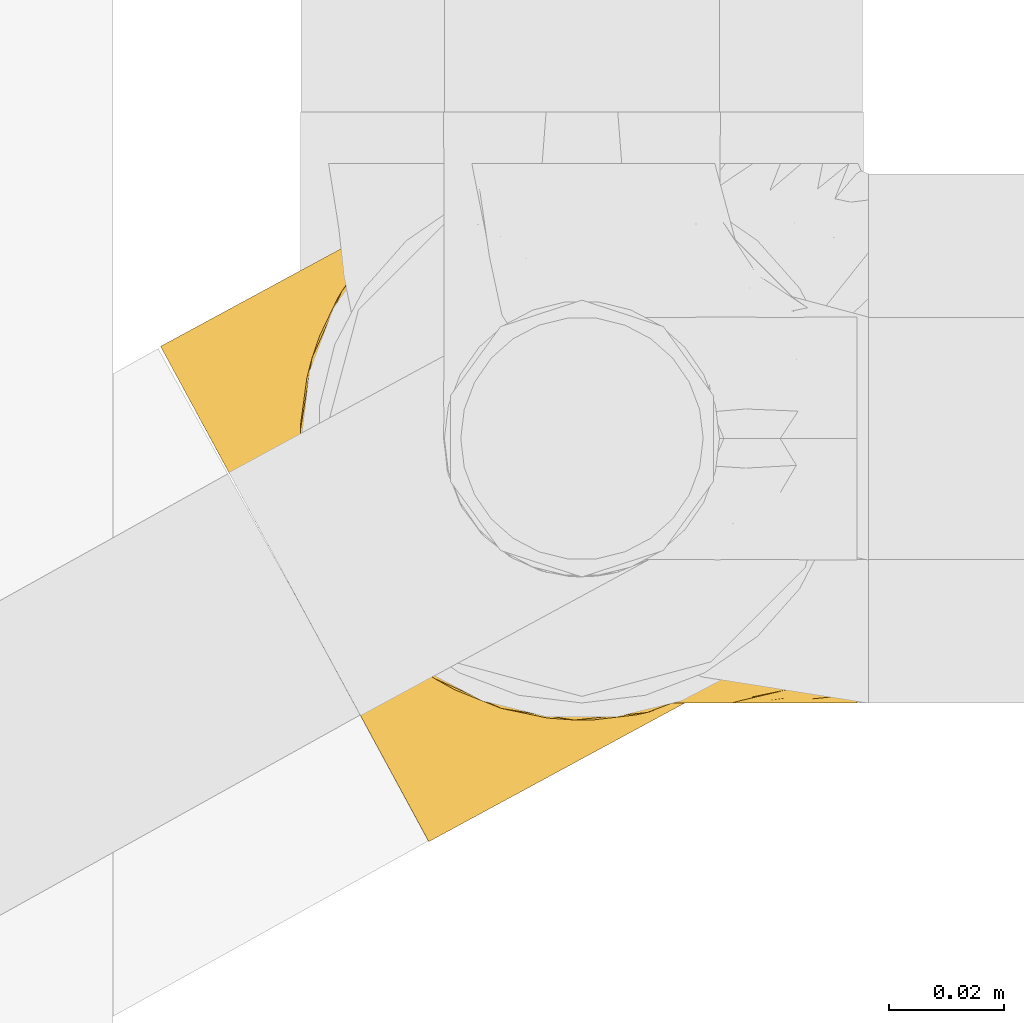
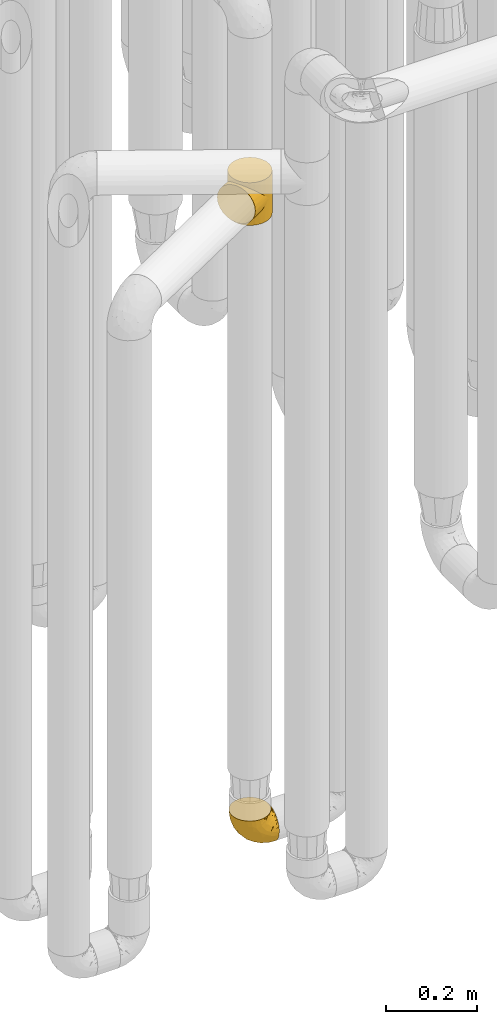
# One storey, part 146 of 827: 2 coverings.
"""IFC2X3 building model written with IfcOpenShell, lengths in millimetres."""

from ifc_helpers import new_model, entity, si_unit, converted_unit, derived_unit, direction, frame, origin, place, context, subcontext, project, spatial, faceted_brep, element, save


model = new_model("IFC2X3")

# Units and contexts
model_context = context("Model", 3, precision=0.01, world=origin(), true_north=direction((6.12303176911189e-17, 1.0)))
body_context = subcontext(model_context, "Body", "Model", "MODEL_VIEW")
ifc_project = project(units=[si_unit("LENGTHUNIT", "METRE", prefix="MILLI"), si_unit("AREAUNIT", "SQUARE_METRE"), si_unit("VOLUMEUNIT", "CUBIC_METRE"), converted_unit("PLANEANGLEUNIT", "DEGREE", entity("IfcRatioMeasure", 0.0174532925199433), si_unit("PLANEANGLEUNIT", "RADIAN"), dimensions=[0, 0, 0, 0, 0, 0, 0]), si_unit("MASSUNIT", "GRAM", prefix="KILO"), derived_unit("MASSDENSITYUNIT", [(si_unit("MASSUNIT", "GRAM", prefix="KILO"), 1), (si_unit("LENGTHUNIT", "METRE"), -3)]), derived_unit("MOMENTOFINERTIAUNIT", [(si_unit("LENGTHUNIT", "METRE"), 4)]), si_unit("TIMEUNIT", "SECOND"), si_unit("FREQUENCYUNIT", "HERTZ"), si_unit("THERMODYNAMICTEMPERATUREUNIT", "DEGREE_CELSIUS"), derived_unit("THERMALTRANSMITTANCEUNIT", [(si_unit("MASSUNIT", "GRAM", prefix="KILO"), 1), (si_unit("THERMODYNAMICTEMPERATUREUNIT", "KELVIN"), -1), (si_unit("TIMEUNIT", "SECOND"), -3)]), derived_unit("VOLUMETRICFLOWRATEUNIT", [(si_unit("LENGTHUNIT", "METRE"), 3), (si_unit("TIMEUNIT", "SECOND"), -1)]), derived_unit("MASSFLOWRATEUNIT", [(si_unit("MASSUNIT", "GRAM", prefix="KILO"), 1), (si_unit("TIMEUNIT", "SECOND"), -1)]), derived_unit("ROTATIONALFREQUENCYUNIT", [(si_unit("TIMEUNIT", "SECOND"), -1)]), si_unit("ELECTRICCURRENTUNIT", "AMPERE"), si_unit("ELECTRICVOLTAGEUNIT", "VOLT"), si_unit("POWERUNIT", "WATT"), si_unit("FORCEUNIT", "NEWTON", prefix="KILO"), si_unit("ILLUMINANCEUNIT", "LUX"), si_unit("LUMINOUSFLUXUNIT", "LUMEN"), si_unit("LUMINOUSINTENSITYUNIT", "CANDELA"), derived_unit("USERDEFINED", [(si_unit("MASSUNIT", "GRAM", prefix="KILO"), -1), (si_unit("LENGTHUNIT", "METRE"), -2), (si_unit("TIMEUNIT", "SECOND"), 3), (si_unit("LUMINOUSFLUXUNIT", "LUMEN"), 1)]), derived_unit("LINEARVELOCITYUNIT", [(si_unit("LENGTHUNIT", "METRE"), 1), (si_unit("TIMEUNIT", "SECOND"), -1)]), si_unit("PRESSUREUNIT", "PASCAL"), derived_unit("USERDEFINED", [(si_unit("LENGTHUNIT", "METRE"), -2), (si_unit("MASSUNIT", "GRAM", prefix="KILO"), 1), (si_unit("TIMEUNIT", "SECOND"), -2)]), derived_unit("LINEARFORCEUNIT", [(si_unit("MASSUNIT", "GRAM", prefix="KILO"), 1), (si_unit("LENGTHUNIT", "METRE"), 1), (si_unit("TIMEUNIT", "SECOND"), -2), (si_unit("LENGTHUNIT", "METRE"), -1)]), derived_unit("PLANARFORCEUNIT", [(si_unit("MASSUNIT", "GRAM", prefix="KILO"), 1), (si_unit("LENGTHUNIT", "METRE"), 1), (si_unit("TIMEUNIT", "SECOND"), -2), (si_unit("LENGTHUNIT", "METRE"), -2)])], contexts=[model_context])

# Site, building, storey
site_placement = place(None, origin())
site = spatial("IfcSite", under=ifc_project, at=site_placement, CompositionType="ELEMENT")
building_placement = place(site_placement, origin())
building = spatial("IfcBuilding", under=site, at=building_placement, CompositionType="ELEMENT")
storey_placement = place(building_placement, frame((0.0, 0.0, 28200.0)))
storey = spatial("IfcBuildingStorey", under=building, at=storey_placement, Name="08", CompositionType="ELEMENT", Elevation=28200.0)

# Coverings
covering_1_placement = place(storey_placement, frame((35680.25, 10558.41, 352.2)))
element("IfcCovering", 1, at=covering_1_placement, inside=storey, Name=":ADSK_", ObjectType=":ADSK_", PredefinedType="INSULATION", context=body_context, shape_type="Brep", body=[
    faceted_brep([(18.98, 83.91, 95.8), (11.67, 76.59, 95.8), (6.17, 67.83, 95.8), (2.75, 58.07, 95.8), (1.6, 47.8, 95.8), (2.75, 37.51, 95.8), (6.17, 27.74, 95.8), (11.68, 18.98, 95.8), (19.0, 11.67, 95.8), (27.76, 6.17, 95.8), (37.52, 2.75, 95.8), (47.8, 1.6, 95.8), (51.94, 2.06, 95.8), (55.01, 2.41, 95.8), (58.08, 2.75, 95.8), (62.96, 4.46, 95.8), (67.85, 6.17, 95.8), (72.23, 8.93, 95.8), (76.61, 11.68, 95.8), (80.26, 15.34, 95.8), (83.92, 19.0, 95.8), (89.42, 27.76, 95.8), (91.13, 32.64, 95.8), (92.84, 37.52, 95.8), (94.0, 47.8, 95.8), (92.84, 58.08, 95.8), (91.13, 62.96, 95.8), (89.42, 67.85, 95.8), (83.91, 76.61, 95.8), (80.25, 80.26, 95.8), (76.59, 83.92, 95.8), (72.21, 86.67, 95.8), (67.83, 89.42, 95.8), (62.95, 91.13, 95.8), (58.07, 92.84, 95.8), (55.0, 93.18, 95.8), (51.94, 93.53, 95.8), (47.8, 94.0, 95.8), (37.51, 92.84, 95.8), (27.74, 89.42, 95.8), (95.8, 47.8, 94.0), (95.8, 35.84, 92.42), (95.8, 24.7, 87.81), (95.8, 19.91, 84.13), (95.8, 15.13, 80.46), (95.8, 11.46, 75.68), (95.8, 7.78, 70.9), (95.8, 5.48, 65.32), (95.8, 3.17, 59.75), (95.8, 2.69, 56.14), (95.8, 2.42, 54.06), (95.8, 2.14, 51.97), (95.8, 1.6, 47.8), (95.8, 3.17, 35.84), (95.8, 7.78, 24.7), (95.8, 15.13, 15.13), (95.8, 24.7, 7.78), (95.8, 35.84, 3.17), (95.8, 47.8, 1.6), (95.8, 59.75, 3.17), (95.8, 70.9, 7.78), (95.8, 80.46, 15.13), (95.8, 87.81, 24.7), (95.8, 92.42, 35.84), (95.8, 94.0, 47.8), (95.8, 93.45, 51.97), (95.8, 92.9, 56.14), (95.8, 92.42, 59.75), (95.8, 90.11, 65.32), (95.8, 87.81, 70.9), (95.8, 84.13, 75.68), (95.8, 80.46, 80.46), (95.8, 75.68, 84.13), (95.8, 70.9, 87.81), (95.8, 59.75, 92.42), (60.58, 71.98, 15.84), (74.11, 63.6, 6.99), (51.59, 59.72, 14.39), (66.69, 47.8, 6.21), (76.19, 55.16, 4.26), (84.43, 47.8, 3.39), (31.2, 63.76, 31.2), (42.88, 72.22, 26.47), (79.41, 74.18, 11.44), (60.7, 92.52, 47.66), (61.85, 94.0, 61.85), (65.75, 94.0, 59.25), (69.64, 94.0, 56.65), (73.53, 94.0, 54.05), (77.43, 94.0, 51.45), (74.59, 82.14, 19.8), (54.72, 80.34, 26.22), (64.18, 87.52, 31.58), (37.94, 79.59, 38.36), (25.89, 78.25, 51.54), (34.73, 85.01, 51.6), (42.89, 90.25, 55.97), (49.83, 93.2, 62.88), (48.58, 87.23, 41.35), (22.41, 85.55, 82.24), (78.69, 93.0, 40.88), (81.64, 89.31, 29.0), (6.22, 61.31, 74.06), (12.11, 56.86, 54.53), (14.81, 68.34, 57.98), (21.61, 65.71, 43.81), (22.41, 56.99, 38.22), (30.12, 72.15, 38.33), (10.01, 70.34, 74.76), (15.36, 78.36, 76.85), (3.39, 47.8, 84.43), (19.59, 47.8, 40.43), (30.01, 47.8, 30.01), (41.19, 93.06, 78.67), (48.54, 94.0, 92.06), (49.28, 94.0, 88.32), (49.82, 94.0, 85.6), (50.37, 94.0, 82.88), (50.91, 94.0, 80.15), (51.45, 94.0, 77.43), (31.61, 89.88, 76.36), (80.15, 94.0, 50.91), (82.88, 94.0, 50.37), (85.6, 94.0, 49.82), (88.32, 94.0, 49.28), (90.19, 94.0, 48.91), (92.06, 94.0, 48.54), (6.21, 47.8, 66.69), (54.05, 94.0, 73.53), (56.65, 94.0, 69.64), (59.25, 94.0, 65.75), (24.66, 83.7, 66.13), (40.43, 47.8, 19.59), (35.17, 55.9, 24.64), (12.9, 47.8, 53.56), (53.56, 47.8, 12.9), (85.34, 81.75, 82.81), (78.44, 86.43, 81.22), (84.37, 79.8, 86.57), (89.05, 69.84, 92.75), (82.76, 79.5, 89.68), (86.31, 88.08, 72.26), (83.73, 91.6, 64.73), (77.31, 92.93, 62.45), (87.78, 92.43, 60.63), (87.91, 93.24, 56.91), (81.29, 93.36, 58.14), (93.97, 57.25, 93.7), (70.76, 89.41, 83.4), (63.67, 92.89, 75.54), (62.62, 92.66, 79.46), (90.64, 79.58, 82.28), (84.08, 86.51, 76.25), (76.28, 86.29, 84.69), (77.45, 83.91, 90.18), (88.72, 90.94, 65.12), (71.28, 91.94, 71.71), (68.09, 91.98, 75.21), (91.07, 82.79, 78.6), (57.47, 93.16, 87.27), (70.34, 88.76, 87.92), (91.35, 73.94, 86.94), (62.99, 91.89, 86.1), (94.52, 47.8, 94.52), (76.47, 92.22, 66.23), (69.96, 88.56, 91.08), (89.86, 87.72, 71.77), (78.94, 88.33, 76.21), (73.51, 92.18, 68.59), (89.62, 71.78, 89.94), (84.09, 9.09, 76.25), (86.3, 7.51, 72.26), (91.06, 12.8, 78.6), (88.32, 1.6, 49.28), (92.06, 1.6, 48.54), (82.88, 1.6, 50.37), (85.6, 1.6, 49.82), (93.97, 38.35, 93.7), (89.63, 23.84, 89.95), (50.37, 1.6, 82.88), (49.82, 1.6, 85.6), (48.54, 1.6, 92.06), (49.28, 1.6, 88.32), (82.77, 16.1, 89.68), (70.36, 6.84, 87.92), (77.31, 2.66, 62.45), (76.47, 3.37, 66.24), (69.64, 1.6, 56.65), (65.75, 1.6, 59.25), (87.78, 3.16, 60.63), (87.91, 2.35, 56.91), (89.06, 25.77, 92.76), (90.65, 16.02, 82.28), (85.35, 13.85, 82.81), (73.53, 1.6, 54.05), (77.43, 1.6, 51.45), (81.29, 2.23, 58.14), (77.46, 11.69, 90.18), (76.29, 9.31, 84.7), (57.47, 2.43, 87.25), (63.71, 2.71, 75.58), (68.11, 3.61, 75.2), (70.77, 6.18, 83.39), (71.31, 3.66, 71.7), (78.46, 9.17, 81.22), (69.52, 6.77, 90.73), (62.64, 2.93, 79.47), (91.35, 21.66, 86.94), (59.25, 1.6, 65.75), (84.6, 16.09, 86.75), (62.98, 3.7, 86.08), (51.45, 1.6, 77.43), (54.05, 1.6, 73.53), (56.65, 1.6, 69.64), (83.73, 3.99, 64.73), (80.15, 1.6, 50.91), (88.72, 4.65, 65.12), (61.85, 1.6, 61.85), (73.56, 3.43, 68.62), (78.96, 7.27, 76.22), (91.36, 9.46, 74.03), (50.91, 1.6, 80.15), (62.87, 2.4, 49.81), (76.19, 40.43, 4.26), (73.57, 13.57, 19.95), (56.07, 11.3, 30.61), (49.77, 18.65, 25.71), (44.73, 27.26, 22.43), (60.58, 23.61, 15.85), (47.64, 3.07, 60.69), (78.32, 2.69, 40.49), (51.59, 35.87, 14.39), (74.11, 31.99, 6.99), (76.04, 6.71, 29.56), (79.41, 21.41, 11.45), (14.82, 27.24, 57.98), (6.22, 34.26, 74.06), (12.12, 38.73, 54.52), (23.51, 26.97, 43.47), (31.2, 31.83, 31.2), (34.96, 23.4, 33.27), (33.86, 6.91, 64.26), (38.94, 3.4, 74.29), (30.23, 5.84, 80.41), (35.17, 39.69, 24.64), (15.85, 17.6, 73.62), (22.59, 10.38, 78.98), (21.56, 20.6, 53.69), (55.94, 5.36, 42.86), (20.67, 35.73, 41.67), (9.19, 24.84, 79.66), (25.79, 13.87, 58.41), (41.16, 9.06, 47.11), (37.95, 15.99, 38.37)], [[[0, 1, 2, 3, 4, 5, 6, 7, 8, 9, 10, 11, 12, 13, 14, 15, 16, 17, 18, 19, 20, 21, 22, 23, 24, 25, 26, 27, 28, 29, 30, 31, 32, 33, 34, 35, 36, 37, 38, 39]], [[40, 41, 42, 43, 44, 45, 46, 47, 48, 49, 50, 51, 52, 53, 54, 55, 56, 57, 58, 59, 60, 61, 62, 63, 64, 65, 66, 67, 68, 69, 70, 71, 72, 73, 74]], [[75, 76, 77]], [[78, 79, 80]], [[77, 81, 82]], [[76, 75, 83]], [[84, 85, 86, 87, 88, 89]], [[90, 91, 92]], [[76, 60, 59]], [[93, 94, 95]], [[90, 62, 61]], [[83, 61, 60]], [[96, 97, 84]], [[98, 93, 95]], [[0, 39, 99]], [[100, 84, 89]], [[62, 101, 63]], [[2, 102, 3]], [[92, 84, 100]], [[103, 102, 104]], [[103, 105, 106]], [[93, 107, 94]], [[1, 108, 2]], [[92, 101, 90]], [[108, 1, 109]], [[102, 110, 3]], [[93, 82, 107]], [[102, 108, 104]], [[111, 106, 112]], [[109, 0, 99]], [[113, 37, 114, 115, 116, 117, 118, 119]], [[120, 38, 113]], [[100, 89, 121, 122, 123, 124, 125, 126, 64]], [[127, 102, 103]], [[97, 119, 128, 129, 130, 85]], [[99, 120, 131]], [[132, 133, 77]], [[59, 80, 79]], [[1, 0, 109]], [[98, 84, 92]], [[94, 109, 131]], [[120, 39, 38]], [[93, 91, 82]], [[104, 94, 105]], [[97, 113, 119]], [[95, 120, 96]], [[83, 90, 61]], [[91, 93, 98]], [[64, 63, 100]], [[100, 63, 101]], [[77, 76, 79]], [[133, 106, 81]], [[84, 97, 85]], [[113, 96, 120]], [[113, 97, 96]], [[37, 113, 38]], [[110, 102, 127]], [[110, 4, 3]], [[103, 111, 134, 127]], [[90, 75, 91]], [[82, 81, 107]], [[91, 75, 82]], [[77, 82, 75]], [[76, 83, 60]], [[90, 83, 75]], [[105, 107, 81]], [[94, 131, 95]], [[105, 94, 107]], [[109, 94, 104]], [[120, 95, 131]], [[98, 95, 96]], [[84, 98, 96]], [[98, 92, 91]], [[106, 105, 81]], [[103, 104, 105]], [[112, 106, 133]], [[103, 106, 111]], [[112, 133, 132]], [[81, 77, 133]], [[77, 78, 135, 132]], [[120, 99, 39]], [[109, 99, 131]], [[59, 58, 80]], [[59, 79, 76]], [[90, 101, 62]], [[100, 101, 92]], [[2, 108, 102]], [[109, 104, 108]], [[78, 77, 79]], [[136, 137, 138]], [[27, 139, 140]], [[141, 142, 143]], [[144, 145, 121]], [[146, 89, 88]], [[147, 139, 25]], [[148, 149, 150]], [[136, 151, 152]], [[147, 40, 74]], [[24, 147, 25]], [[140, 153, 154]], [[33, 116, 34]], [[73, 72, 151]], [[114, 37, 36, 35, 34, 116, 115]], [[146, 155, 144]], [[156, 85, 130]], [[157, 149, 148]], [[151, 158, 152]], [[117, 33, 159]], [[29, 154, 160]], [[161, 74, 73]], [[162, 128, 119]], [[66, 65, 64, 126, 125, 124, 123, 122, 67]], [[163, 147, 24]], [[27, 140, 28]], [[149, 129, 150]], [[139, 27, 26, 25]], [[68, 144, 69]], [[129, 128, 150]], [[164, 87, 86]], [[130, 129, 149]], [[122, 145, 67]], [[154, 153, 148]], [[162, 119, 159]], [[165, 30, 160]], [[150, 160, 148]], [[128, 162, 150]], [[30, 165, 31]], [[145, 144, 68]], [[89, 146, 144]], [[87, 164, 143]], [[166, 155, 142]], [[88, 87, 143]], [[162, 160, 150]], [[160, 30, 29]], [[154, 29, 28]], [[140, 154, 28]], [[160, 154, 148]], [[140, 137, 153]], [[157, 148, 153]], [[156, 130, 157]], [[153, 137, 157]], [[157, 137, 156]], [[167, 137, 136]], [[168, 85, 156]], [[152, 168, 167]], [[167, 168, 156]], [[164, 152, 141]], [[71, 158, 72]], [[152, 167, 136]], [[88, 142, 146]], [[144, 155, 69]], [[146, 142, 155]], [[70, 166, 71]], [[142, 141, 166]], [[70, 69, 155]], [[141, 158, 71]], [[161, 73, 151]], [[138, 137, 140]], [[161, 136, 169]], [[136, 161, 151]], [[74, 161, 169]], [[152, 158, 141]], [[151, 72, 158]], [[168, 152, 164]], [[137, 167, 156]], [[164, 86, 168]], [[85, 168, 86]], [[116, 33, 117]], [[130, 149, 157]], [[67, 145, 68]], [[121, 89, 144]], [[145, 122, 121]], [[40, 147, 163]], [[169, 147, 74]], [[159, 33, 32]], [[162, 159, 32]], [[159, 119, 118, 117]], [[139, 147, 169]], [[139, 169, 138]], [[162, 32, 31]], [[141, 143, 164]], [[88, 143, 142]], [[71, 166, 141]], [[155, 166, 70]], [[139, 138, 140]], [[169, 136, 138]], [[160, 162, 165]], [[162, 31, 165]], [[170, 171, 172]], [[173, 174, 52, 51, 50, 49, 48, 175, 176]], [[177, 178, 41]], [[179, 15, 180]], [[12, 11, 181, 182, 180, 14, 13]], [[183, 21, 20]], [[19, 18, 184]], [[185, 186, 187]], [[186, 188, 187]], [[43, 172, 44]], [[189, 190, 47]], [[23, 22, 21, 191]], [[170, 192, 193]], [[40, 163, 177]], [[194, 195, 196]], [[24, 23, 177]], [[197, 198, 183]], [[199, 15, 179]], [[47, 46, 189]], [[200, 201, 202]], [[201, 203, 204]], [[205, 206, 184]], [[207, 41, 178]], [[16, 15, 199]], [[14, 180, 15]], [[202, 201, 198]], [[208, 201, 200]], [[163, 24, 177]], [[48, 47, 190]], [[196, 195, 189]], [[197, 184, 202]], [[204, 193, 209]], [[210, 211, 212]], [[206, 212, 213]], [[205, 17, 210]], [[184, 206, 202]], [[210, 212, 206]], [[185, 194, 214]], [[189, 215, 190]], [[216, 45, 214]], [[186, 171, 170]], [[189, 216, 196]], [[197, 20, 19]], [[194, 185, 187]], [[197, 183, 20]], [[184, 197, 19]], [[197, 202, 198]], [[206, 200, 202]], [[204, 183, 198]], [[201, 208, 203]], [[203, 208, 217]], [[204, 198, 201]], [[217, 188, 218]], [[193, 219, 170]], [[171, 186, 185]], [[170, 218, 186]], [[170, 219, 218]], [[42, 207, 192]], [[171, 220, 172]], [[216, 189, 46]], [[214, 194, 196]], [[44, 220, 45]], [[214, 196, 216]], [[216, 46, 45]], [[214, 45, 220]], [[192, 43, 42]], [[204, 203, 219]], [[207, 193, 192]], [[209, 193, 178]], [[41, 207, 42]], [[193, 207, 178]], [[43, 192, 172]], [[170, 172, 192]], [[204, 219, 193]], [[219, 203, 218]], [[217, 218, 203]], [[188, 186, 218]], [[206, 213, 200]], [[208, 200, 213]], [[199, 210, 16]], [[215, 189, 195]], [[215, 175, 190]], [[175, 48, 190]], [[199, 179, 221, 211]], [[210, 199, 211]], [[23, 191, 177]], [[40, 177, 41]], [[178, 177, 191]], [[21, 183, 191]], [[209, 191, 183]], [[205, 18, 17]], [[17, 16, 210]], [[171, 185, 214]], [[172, 220, 44]], [[214, 220, 171]], [[191, 209, 178]], [[204, 209, 183]], [[206, 205, 210]], [[18, 205, 184]], [[222, 195, 194, 187, 188, 217]], [[57, 223, 80]], [[224, 225, 226]], [[226, 227, 228]], [[229, 217, 208, 213, 212, 211]], [[230, 52, 174, 173, 176, 175, 215, 195]], [[231, 232, 228]], [[231, 78, 223]], [[223, 57, 232]], [[224, 233, 225]], [[233, 54, 53]], [[234, 232, 56]], [[56, 55, 234]], [[234, 224, 228]], [[235, 236, 237]], [[224, 55, 54]], [[238, 239, 240]], [[52, 230, 53]], [[241, 242, 243]], [[227, 244, 231]], [[11, 10, 242]], [[236, 6, 5]], [[7, 245, 8]], [[8, 246, 9]], [[238, 247, 235]], [[222, 229, 248]], [[242, 211, 221, 179, 180, 182, 181, 11]], [[233, 53, 230]], [[111, 112, 249]], [[250, 6, 236]], [[246, 251, 241]], [[6, 250, 7]], [[127, 236, 110]], [[248, 229, 252]], [[246, 8, 245]], [[235, 245, 250]], [[236, 5, 110]], [[235, 249, 238]], [[237, 236, 127]], [[243, 9, 246]], [[252, 229, 241]], [[56, 232, 57]], [[222, 230, 195]], [[225, 248, 252]], [[248, 233, 230]], [[54, 233, 224]], [[231, 228, 227]], [[244, 132, 231]], [[248, 225, 233]], [[226, 225, 253]], [[235, 250, 236]], [[245, 7, 250]], [[251, 246, 245]], [[243, 246, 241]], [[247, 245, 235]], [[252, 251, 253]], [[229, 222, 217]], [[230, 222, 248]], [[5, 4, 110]], [[237, 127, 134, 111]], [[238, 249, 239]], [[224, 234, 55]], [[232, 234, 228]], [[242, 241, 229]], [[10, 9, 243]], [[211, 242, 229]], [[10, 243, 242]], [[80, 223, 78]], [[80, 58, 57]], [[231, 223, 232]], [[227, 240, 239]], [[224, 226, 228]], [[240, 226, 253]], [[227, 239, 244]], [[226, 240, 227]], [[251, 247, 253]], [[240, 253, 247]], [[249, 235, 237]], [[237, 111, 249]], [[112, 132, 244]], [[112, 244, 249]], [[78, 231, 132, 135]], [[249, 244, 239]], [[247, 238, 240]], [[245, 247, 251]], [[251, 252, 241]], [[225, 252, 253]]]),
])
covering_2_placement = place(storey_placement, frame((35652.92, 10534.25, 2043.0)))
element("IfcCovering", 2, at=covering_2_placement, inside=storey, Name=":ADSK_", ObjectType=":ADSK_", PredefinedType="INSULATION", context=body_context, shape_type="Brep", body=[
    faceted_brep([(33.78, 45.96, 0.0), (35.67, 43.36, 0.0), (34.83, 44.29, 8.4), (37.76, 40.02, 8.94), (37.55, 40.76, 0.0), (39.43, 38.16, 0.0), (44.97, 33.14, 12.0), (44.41, 34.12, 0.0), (49.39, 30.08, 0.0), (41.37, 36.58, 10.47), (52.88, 28.13, 16.57), (55.25, 27.46, 0.0), (61.03, 24.87, 22.18), (48.92, 30.64, 14.29), (33.37, 46.42, 8.12), (31.9, 48.55, 0.0), (61.11, 24.85, 0.0), (69.13, 23.17, 28.5), (73.78, 22.83, 0.0), (77.03, 22.84, 35.29), (86.54, 24.15, 0.0), (91.8, 25.72, 49.65), (98.53, 28.74, 0.0), (31.9, 48.55, 7.85), (33.37, 46.42, 105.88), (31.9, 48.55, 114.0), (31.9, 48.55, 106.15), (84.61, 23.73, 42.38), (98.53, 28.74, 57.0), (91.8, 25.72, 64.35), (98.53, 28.74, 114.0), (46.11, 111.63, 50.38), (51.72, 115.18, 0.0), (41.33, 107.65, 0.0), (33.24, 97.68, 0.0), (36.42, 102.26, 37.4), (29.35, 89.87, 25.28), (28.01, 85.97, 0.0), (32.5, 96.44, 31.18), (51.72, 115.18, 57.0), (46.11, 111.63, 63.62), (51.72, 115.18, 114.0), (30.08, 52.85, 8.29), (29.61, 54.55, 0.0), (30.76, 51.55, 0.0), (40.99, 107.32, 43.83), (30.76, 51.55, 114.0), (27.13, 82.55, 19.84), (25.99, 73.3, 0.0), (26.65, 66.92, 0.0), (27.32, 60.54, 0.0), (27.3, 61.56, 10.0), (28.26, 57.15, 8.74), (26.04, 74.54, 15.07), (26.34, 65.98, 11.25), (28.46, 57.54, 0.0), (124.25, 70.62, 114.0), (122.93, 83.38, 114.0), (118.34, 95.36, 114.0), (110.81, 105.75, 114.0), (100.85, 113.84, 114.0), (89.13, 119.07, 114.0), (76.46, 121.09, 114.0), (63.7, 119.76, 114.0), (41.33, 107.65, 114.0), (33.24, 97.68, 114.0), (28.01, 85.97, 114.0), (25.99, 73.3, 114.0), (26.65, 66.92, 114.0), (27.32, 60.54, 114.0), (28.46, 57.54, 114.0), (29.61, 54.55, 114.0), (33.78, 45.96, 114.0), (35.67, 43.36, 114.0), (37.55, 40.76, 114.0), (39.43, 38.16, 114.0), (44.41, 34.12, 114.0), (49.39, 30.08, 114.0), (55.25, 27.46, 114.0), (61.11, 24.85, 114.0), (73.78, 22.83, 114.0), (86.54, 24.15, 114.0), (108.92, 36.27, 114.0), (117.0, 46.23, 114.0), (122.23, 57.95, 114.0), (63.7, 119.76, 0.0), (76.46, 121.09, 0.0), (89.13, 119.07, 0.0), (100.85, 113.84, 0.0), (110.81, 105.75, 0.0), (118.34, 95.36, 0.0), (122.93, 83.38, 0.0), (124.25, 70.62, 0.0), (122.23, 57.95, 0.0), (117.0, 46.23, 0.0), (108.92, 36.27, 0.0), (40.99, 107.32, 70.17), (36.42, 102.26, 76.6), (30.08, 52.85, 105.71), (32.5, 96.44, 82.82), (29.35, 89.87, 88.72), (28.26, 57.15, 105.26), (27.13, 82.55, 94.16), (26.04, 74.54, 98.93), (27.3, 61.56, 104.0), (26.34, 65.98, 102.75), (44.97, 33.14, 102.0), (41.37, 36.58, 103.53), (52.88, 28.13, 97.43), (37.76, 40.02, 105.06), (61.03, 24.87, 91.82), (48.92, 30.64, 99.71), (34.83, 44.29, 105.6), (77.03, 22.84, 78.71), (84.61, 23.73, 71.62), (69.13, 23.17, 85.5), (2.39, 86.56, 44.28), (4.73, 82.24, 32.42), (8.45, 75.38, 22.25), (13.3, 66.43, 14.43), (16.12, 61.21, 11.98), (18.94, 56.0, 9.52), (20.46, 53.2, 9.11), (21.97, 50.41, 8.69), (23.48, 47.61, 8.27), (25.0, 44.82, 7.85), (26.51, 42.02, 8.27), (28.03, 39.22, 8.69), (29.54, 36.43, 9.11), (31.06, 33.63, 9.52), (33.88, 28.42, 11.98), (36.7, 23.21, 14.43), (39.12, 18.73, 18.34), (41.55, 14.25, 22.25), (45.27, 7.39, 32.42), (47.61, 3.07, 44.28), (48.4, 1.6, 57.0), (47.61, 3.07, 69.72), (45.27, 7.39, 81.57), (41.55, 14.25, 91.75), (39.12, 18.73, 95.66), (36.7, 23.21, 99.57), (33.88, 28.42, 102.02), (31.06, 33.63, 104.48), (29.54, 36.43, 104.89), (28.03, 39.22, 105.31), (26.51, 42.02, 105.73), (25.0, 44.82, 106.15), (23.48, 47.61, 105.73), (21.97, 50.41, 105.31), (20.46, 53.2, 104.89), (18.94, 56.0, 104.48), (16.12, 61.21, 102.02), (13.3, 66.43, 99.57), (8.45, 75.38, 91.75), (4.73, 82.24, 81.57), (2.39, 86.56, 69.72), (1.6, 88.04, 57.0)], [[[0, 1, 2]], [[3, 1, 4, 5]], [[6, 7, 8]], [[9, 7, 6]], [[9, 3, 5]], [[10, 8, 11]], [[12, 10, 11]], [[6, 8, 10, 13]], [[14, 15, 0]], [[11, 16, 12]], [[17, 16, 18]], [[19, 18, 20]], [[21, 20, 22]], [[19, 17, 18]], [[15, 14, 23]], [[24, 25, 26]], [[21, 27, 20]], [[28, 21, 22]], [[29, 28, 30]], [[1, 3, 2]], [[19, 20, 27]], [[7, 9, 5]], [[16, 17, 12]], [[0, 2, 14]], [[31, 32, 33]], [[33, 34, 35]], [[36, 34, 37]], [[36, 38, 34]], [[31, 39, 32]], [[39, 40, 41]], [[42, 43, 44]], [[35, 45, 33]], [[38, 35, 34]], [[31, 33, 45]], [[23, 44, 15]], [[46, 26, 25]], [[47, 37, 48]], [[49, 50, 51]], [[23, 42, 44]], [[50, 52, 51]], [[53, 47, 48]], [[54, 48, 49]], [[54, 49, 51]], [[52, 43, 42]], [[52, 50, 55, 43]], [[53, 48, 54]], [[37, 47, 36]], [[56, 57, 58, 59, 60, 61, 62, 63, 41, 64, 65, 66, 67, 68, 69, 70, 71, 46, 25, 72, 73, 74, 75, 76, 77, 78, 79, 80, 81, 30, 82, 83, 84]], [[85, 86, 87, 88, 89, 90, 91, 92, 93, 94, 95, 22, 20, 18, 16, 11, 8, 7, 5, 4, 1, 0, 15, 44, 43, 55, 50, 49, 48, 37, 34, 33, 32]], [[88, 87, 61, 60]], [[58, 90, 89, 59]], [[89, 88, 60, 59]], [[62, 86, 85, 63]], [[32, 39, 41, 63, 85]], [[61, 87, 86, 62]], [[96, 97, 64]], [[26, 46, 98]], [[40, 96, 64]], [[41, 40, 64]], [[65, 99, 100]], [[65, 64, 97]], [[71, 101, 98]], [[65, 100, 66]], [[99, 65, 97]], [[102, 103, 67]], [[104, 68, 105]], [[104, 101, 69]], [[68, 104, 69]], [[103, 105, 67]], [[66, 102, 67]], [[101, 71, 70, 69]], [[68, 67, 105]], [[98, 46, 71]], [[102, 66, 100]], [[106, 76, 107]], [[106, 77, 76]], [[77, 108, 78]], [[109, 75, 74, 73]], [[110, 78, 108]], [[111, 108, 77, 106]], [[25, 24, 72]], [[109, 73, 112]], [[72, 24, 112]], [[76, 75, 107]], [[110, 79, 78]], [[75, 109, 107]], [[113, 114, 81]], [[114, 29, 81]], [[79, 115, 80]], [[115, 79, 110]], [[113, 80, 115]], [[113, 81, 80]], [[29, 30, 81]], [[112, 73, 72]], [[28, 22, 95, 82, 30]], [[82, 95, 94, 83]], [[94, 93, 84, 83]], [[84, 93, 92, 56]], [[56, 92, 91, 57]], [[57, 91, 90, 58]], [[116, 117, 118, 119, 120, 121, 122, 123, 124, 125, 126, 127, 128, 129, 130, 131, 132, 133, 134, 135, 136, 137, 138, 139, 140, 141, 142, 143, 144, 145, 146, 147, 148, 149, 150, 151, 152, 153, 154, 155, 156, 157]], [[52, 123, 122, 121]], [[119, 118, 47]], [[23, 124, 42]], [[54, 120, 119]], [[124, 23, 125]], [[124, 123, 42]], [[120, 51, 121]], [[53, 54, 119]], [[47, 53, 119]], [[51, 120, 54]], [[52, 121, 51]], [[118, 36, 47]], [[38, 36, 117]], [[117, 36, 118]], [[35, 117, 116]], [[31, 116, 157]], [[35, 38, 117]], [[31, 45, 116]], [[39, 31, 157]], [[35, 116, 45]], [[123, 52, 42]], [[40, 157, 156]], [[156, 155, 97]], [[100, 155, 154]], [[100, 99, 155]], [[40, 39, 157]], [[98, 149, 148]], [[97, 96, 156]], [[99, 97, 155]], [[40, 156, 96]], [[26, 148, 147]], [[102, 154, 153]], [[152, 151, 104]], [[26, 98, 148]], [[151, 101, 104]], [[103, 102, 153]], [[105, 153, 152]], [[105, 152, 104]], [[101, 149, 98]], [[101, 151, 150, 149]], [[103, 153, 105]], [[154, 102, 100]], [[146, 145, 112]], [[109, 145, 144, 143]], [[106, 142, 141]], [[107, 142, 106]], [[107, 109, 143]], [[108, 141, 140]], [[110, 108, 140]], [[106, 141, 108, 111]], [[24, 147, 146]], [[140, 139, 110]], [[115, 139, 138]], [[113, 138, 137]], [[29, 137, 136]], [[113, 115, 138]], [[147, 24, 26]], [[29, 114, 137]], [[28, 29, 136]], [[145, 109, 112]], [[113, 137, 114]], [[142, 107, 143]], [[139, 115, 110]], [[146, 112, 24]], [[21, 136, 135]], [[135, 134, 19]], [[17, 134, 133]], [[17, 19, 134]], [[14, 125, 23]], [[21, 28, 136]], [[3, 129, 128, 127]], [[19, 27, 135]], [[21, 135, 27]], [[2, 127, 126]], [[131, 6, 13, 10]], [[125, 14, 126]], [[10, 132, 131]], [[130, 129, 9]], [[14, 2, 126]], [[12, 133, 132]], [[12, 132, 10]], [[6, 130, 9]], [[3, 127, 2]], [[6, 131, 130]], [[129, 3, 9]], [[133, 12, 17]]]),
])

save(model, "model.ifc")
